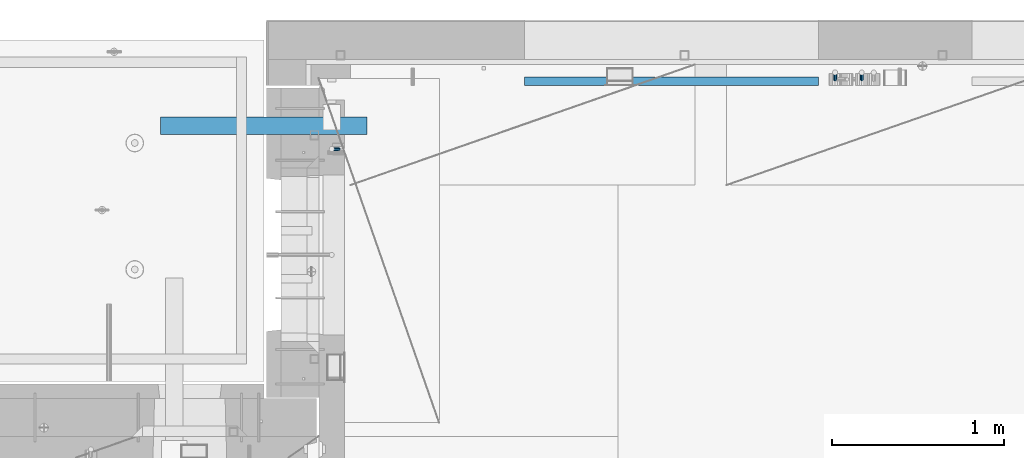
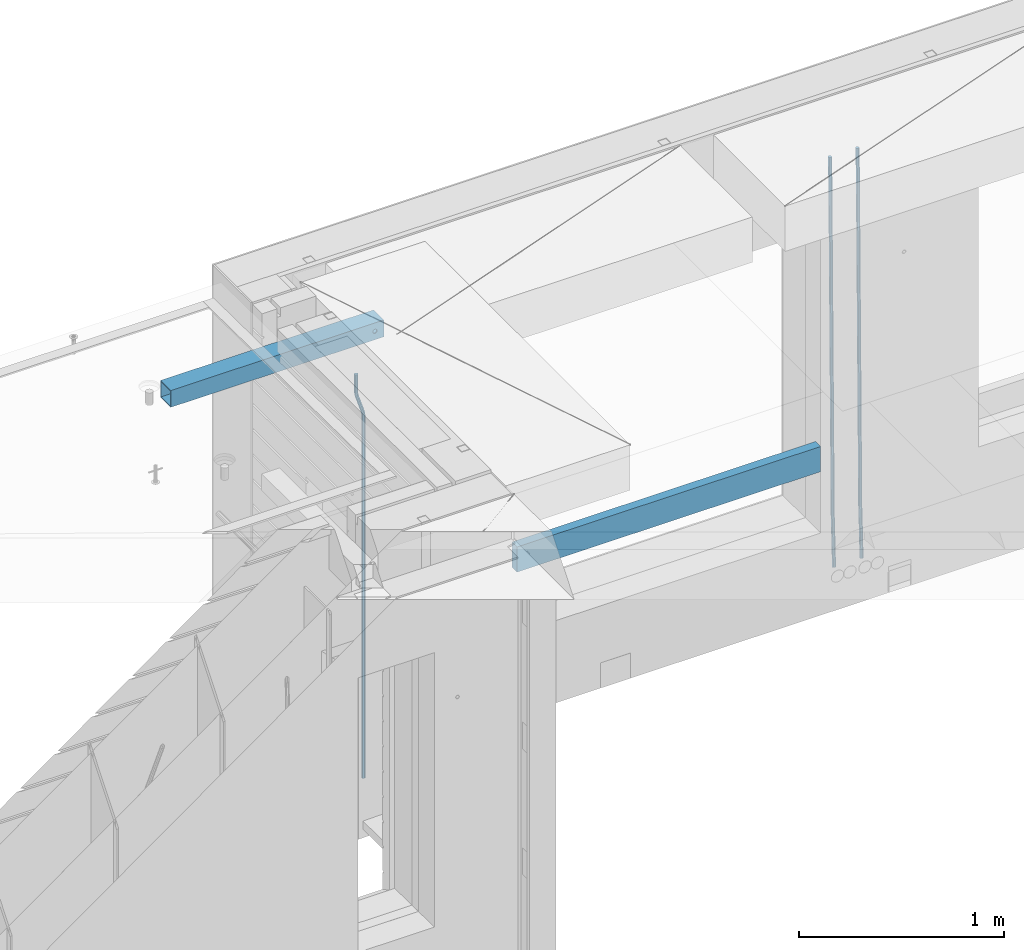
# One storey, part 111 of 334: 5 beams, 4 elements without a shape of their own.
"""IFC2X3 building model written with IfcOpenShell, lengths in millimetres."""

from ifc_helpers import new_model, si_unit, frame, origin_with_axes, place, context, subcontext, project, spatial, faceted_brep, material, type_object, element, aggregate, save


model = new_model("IFC2X3")

# Units and contexts
model_context = context("Model", 3, precision=1e-05, world=origin_with_axes())
body_context = subcontext(model_context, "Body", "Model", "MODEL_VIEW")
ifc_project = project(units=[si_unit("LENGTHUNIT", "METRE", prefix="MILLI"), si_unit("AREAUNIT", "SQUARE_METRE"), si_unit("VOLUMEUNIT", "CUBIC_METRE"), si_unit("MASSUNIT", "GRAM", prefix="KILO"), si_unit("TIMEUNIT", "SECOND"), si_unit("PLANEANGLEUNIT", "RADIAN"), si_unit("SOLIDANGLEUNIT", "STERADIAN"), si_unit("THERMODYNAMICTEMPERATUREUNIT", "DEGREE_CELSIUS"), si_unit("LUMINOUSINTENSITYUNIT", "LUMEN")], contexts=[model_context])

# Site, building, storey
site_placement = place(None, origin_with_axes())
site = spatial("IfcSite", under=ifc_project, at=site_placement, CompositionType="ELEMENT")
building_placement = place(site_placement, origin_with_axes())
building = spatial("IfcBuilding", under=site, at=building_placement, CompositionType="ELEMENT")
storey_placement = place(building_placement, origin_with_axes())
storey = spatial("IfcBuildingStorey", under=building, at=storey_placement, Name="3", CompositionType="ELEMENT", Elevation=0.0)

# Assembly, beams
assembly_1_placement = place(storey_placement, origin_with_axes())
assembly_1 = element("IfcElementAssembly", 1, at=assembly_1_placement, inside=storey, AssemblyPlace="NOTDEFINED", PredefinedType="REINFORCEMENT_UNIT")
ifc_material_1 = material()
beam_type_1 = type_object("IfcBeamType", Name="D20", PredefinedType="NOTDEFINED")
beam_1_placement = place(assembly_1_placement, frame((13990.0000000039, 22654.9999977209, 87990.0), z_axis=(-0.000205762999925498, 0.999642804629538, -0.0267249099901004), x_axis=(4.30000201928125e-08, 0.0267249099948059, 0.999642825806181)))
beam_1 = element("IfcBeam", 2, at=beam_1_placement, type_object=beam_type_1, material=ifc_material_1, Name="JM20", ObjectType="D20", context=body_context, shape_type="Brep", body=[
    faceted_brep([(0.0, -10.0, 0.0), (-4.19531716033816e-08, -7.07106781186667, -7.07106781187031), (60.4266690400545, -7.0710677960451, -7.07106780570757), (60.4266690441291, -9.99999998418934, 6.15546014159918e-09), (0.0, 0.0, -10.0), (60.426669036824, 1.58106558956206e-08, -9.99999999384454), (4.196772351861e-08, 7.07106781186303, -7.07106781186667), (60.4266690363438, 7.07106782768096, -7.07106780570757), (0.0, 10.0, 0.0), (60.4266690388904, 10.0000000158179, 6.15182216279209e-09), (4.196772351861e-08, 7.07106781185939, 7.07106781185939), (60.4266690429649, 7.07106782768096, 7.07106781802577), (0.0, 0.0, 10.0), (60.4266690461809, 1.58179318532348e-08, 10.0000000061555), (-4.19531716033816e-08, -7.07106781187031, 7.07106781185939), (60.4266690466611, -7.07106779605238, 7.07106781802213), (61.0378400410118, -7.07106779588503, -7.07106780564936), (60.991799419251, -9.99999998403655, 6.21366780251265e-09), (61.0569027789461, 1.5985278878361e-08, -9.99999999378269), (61.0378209396877, 7.07106782784831, -7.07106780564936), (60.9917724058905, 10.0000000159635, 6.21366780251265e-09), (60.9457317841297, 7.07106782781193, 7.0710678180767), (60.9266690461809, 1.59488990902901e-08, 10.0000000062028), (60.9457508854539, -7.07106779591413, 7.0710678180767), (61.6489592143771, -7.07106614513759, -7.06310863441468), (61.5568818710308, -9.9999984576425, 0.00735959856683621), (61.6870830769039, 1.71821739058942e-06, -9.99179257185824), (61.6489210170112, 7.07106947854481, -7.06310888312146), (61.556827851804, 10.0000015422847, 0.00735924683976918), (61.4647505084577, 7.07106922979438, 7.07782747982128), (61.4266266459163, 1.36643211590126e-06, 10.0065114172685), (61.464788705809, -7.07106639389531, 7.07782772852806), (176.543135720174, -7.07075579406956, -5.56673531796696), (176.451058376813, -9.99968810657447, 1.50373291501455), (176.581259582701, 0.000312069292704109, -8.49541925541052), (176.543097522794, 7.07137982961285, -5.56673556667374), (176.451004357587, 10.00031189336, 1.50373256329476), (176.35892701424, 7.07137958085514, 8.57420079627263), (176.320803151699, 0.000311717507429421, 11.5028847337162), (176.358965211621, -7.07075604281999, 8.57420104497578), (177.098753836006, -7.07075429323595, -5.55949898843028), (176.98362511232, -9.99968666800123, 1.510669025065), (177.146421932586, 0.000313595905026887, -8.48805862247536), (177.098706077581, 7.07138133041735, -5.55949936166144), (176.983557571715, 10.0003133318824, 1.51066849724157), (176.868428848029, 7.07138095712435, 8.58083651073321), (176.820760751449, 0.000313067976094317, 11.5093961447819), (176.868476606425, -7.07075466652896, 8.58083688396073), (177.654312950661, -7.07075204110879, -5.54863964998367), (177.516135294456, -9.99968450931192, 1.52107783331303), (177.711524267797, 0.000315886711177882, -8.47701274570863), (177.654255632195, 7.07138358250813, -5.54864021007961), (177.516054233929, 10.0003154905207, 1.5210770412159), (177.377876577739, 7.0713830223176, 8.59079452451624), (177.320665260588, 0.000315094497636892, 11.5191676202448), (177.377933896176, -7.07075260129932, 8.59079508461218), (299.436796249574, -7.07025836271714, -3.1681962331204), (299.298618593355, -9.99919083092027, 3.90152125031091), (299.494007566798, 0.000809565110102994, -6.09656932889993), (299.436738931283, 7.07187726089978, -3.16819679320906), (299.298537533061, 10.0008091689197, 3.90152045822106), (299.160359876842, 7.07187670072017, 10.9712379416487), (299.103148559603, 0.000808772889286047, 13.8996110374392), (299.160417195119, -7.07025892290039, 10.9712385017483), (299.98743051647, -7.07025613056248, -3.15743315966392), (299.971788958996, -9.99918809853989, 3.91467979818117), (299.993912075952, 0.000811591617093654, -6.08679785393178), (299.987423933868, 7.07187949325817, -3.1574327280432), (299.971753863239, 10.0008119014747, 3.91467990454839), (299.95611230444, 7.07187992653053, 10.9867922621015), (299.949630744944, 0.000812204350950196, 13.9161569563694), (299.956118887014, -7.07025569729012, 10.9867918304735), (300.538107039494, -7.07025785017686, -3.16575821840888), (300.644985195438, -9.99919020432935, 3.90450175465594), (300.493854948218, 0.000810030429420294, -6.09435592770024), (300.538151196495, 7.071877773491, -3.16575855385963), (300.645047642858, 10.0008097955724, 3.90450128024895), (300.751925798773, 7.07187744142357, 10.9747612533101), (300.796177890064, 0.000809560813650023, 13.9033589625978), (300.751881641787, -7.07025818224065, 10.9747615887682), (2293.36490490142, -7.07648090940347, -33.2930642912361), (2293.47178305736, -10.0054132635523, -26.2228043181785), (2293.32065281013, -0.00541302880083094, -36.2216620005347), (2293.36494905842, 7.06565471425711, -33.2930646266868), (2293.47184550477, 9.99458673634581, -26.2228047925819), (2293.57872366071, 7.06565438219332, -19.1525448195243), (2293.62297575199, -0.00541349841296324, -16.2239471102366), (2293.57867950371, -7.0764812414709, -19.1525444840736), (2294.0658245362, -7.07648309818615, -33.3036607065333), (2294.05312277409, -10.0054150789219, -26.2315929392535), (2294.10928714235, -0.00541549149056664, -36.2335844756526), (2294.15805078732, 7.06565223761572, -33.3050546393533), (2294.18355038921, 9.99458451388637, -26.2335642579346), (2294.17084862708, 7.06565253314329, -19.1614964906439), (2294.12738602093, -0.00541507354500936, -16.2315727215355), (2294.07862237596, -7.07648280265857, -19.1601025578348), (2294.76670261032, -7.08562269121467, -33.294332712383), (2294.63442802057, -10.0129954178956, -26.2238563411993), (2294.89787471293, -0.0156988342423574, -36.2230891548279), (2294.95110548967, 7.05531064255774, -33.2944998654275), (2294.89521307347, 9.98530428734011, -26.2240927312887), (2294.76293848372, 7.0579315606592, -19.1536163601049), (2294.63176638114, -0.0119922963167483, -16.2248599176673), (2294.57853560438, -7.08300177311321, -19.1534492070678), (2316.52657204497, -7.36937582653991, -33.0047303660212), (2316.39429745522, -10.2967485532172, -25.9342539948302), (2316.65774414754, -0.299451969567599, -35.9334868084661), (2316.7109749243, 6.7715575072325, -33.0048975190657), (2316.65508250811, 9.70155115201487, -25.9344903849269), (2316.52280791836, 6.7741784253376, -18.8640140137468), (2316.39163581574, -0.295745431634714, -15.9352575713092), (2316.33840503903, -7.36675490843481, -18.863846860706), (2317.16202064224, -7.37766220584308, -32.9962731735213), (2317.05438744847, -10.3053562613532, -25.9254688497131), (2317.23607125619, -0.306993473008333, -35.925789846493), (2317.23316144495, 6.76474808850253, -32.9979477328052), (2317.15499573652, 9.6950321815566, -25.9278370341635), (2317.04736254275, 6.7673381260538, -18.8570327103698), (2316.97331192881, -0.303330606784584, -15.9275160373909), (2316.97622174003, -7.37507216829545, -18.8553581510787), (2317.79752306276, -7.37578610372293, -32.9880110666527), (2317.71453320107, -10.3033876998124, -25.9168792378296), (2317.81444760226, -0.305295583297266, -35.918287695793), (2317.75539265381, 6.76628640723357, -32.9911928173897), (2317.65495180529, 9.69652304524061, -25.9213789128698), (2317.5719619436, 6.76892144914746, -18.8502470840467), (2317.55503740412, -0.301569071270933, -15.9199704549137), (2317.61409235255, -7.3731510618054, -18.847065333317), (2417.8183084176, -7.07752398473531, -31.6906369377139), (2417.73531855589, -10.0051255808248, -24.6195051088798), (2417.83523295709, -0.007033464313281, -34.6209135668432), (2417.77617800863, 7.06454852621755, -31.6938186884508), (2417.67573716014, 9.99478516423187, -24.6240047839383), (2417.59274729842, 7.06718356813872, -17.5528729551006), (2417.57582275895, -0.00330695228694822, -14.6225963259749), (2417.6348777074, -7.07488894281778, -17.5496912043673)], [[[0, 1, 2, 3]], [[1, 4, 5, 2]], [[4, 6, 7, 5]], [[6, 8, 9, 7]], [[8, 10, 11, 9]], [[10, 12, 13, 11]], [[12, 14, 15, 13]], [[14, 0, 3, 15]], [[14, 12, 10, 8, 6, 4, 1, 0]], [[3, 2, 16, 17]], [[2, 5, 18, 16]], [[5, 7, 19, 18]], [[7, 9, 20, 19]], [[9, 11, 21, 20]], [[11, 13, 22, 21]], [[13, 15, 23, 22]], [[15, 3, 17, 23]], [[17, 16, 24, 25]], [[16, 18, 26, 24]], [[18, 19, 27, 26]], [[19, 20, 28, 27]], [[20, 21, 29, 28]], [[21, 22, 30, 29]], [[22, 23, 31, 30]], [[23, 17, 25, 31]], [[25, 24, 32, 33]], [[24, 26, 34, 32]], [[26, 27, 35, 34]], [[27, 28, 36, 35]], [[28, 29, 37, 36]], [[29, 30, 38, 37]], [[30, 31, 39, 38]], [[31, 25, 33, 39]], [[33, 32, 40, 41]], [[32, 34, 42, 40]], [[34, 35, 43, 42]], [[35, 36, 44, 43]], [[36, 37, 45, 44]], [[37, 38, 46, 45]], [[38, 39, 47, 46]], [[39, 33, 41, 47]], [[41, 40, 48, 49]], [[40, 42, 50, 48]], [[42, 43, 51, 50]], [[43, 44, 52, 51]], [[44, 45, 53, 52]], [[45, 46, 54, 53]], [[46, 47, 55, 54]], [[47, 41, 49, 55]], [[49, 48, 56, 57]], [[48, 50, 58, 56]], [[50, 51, 59, 58]], [[51, 52, 60, 59]], [[52, 53, 61, 60]], [[53, 54, 62, 61]], [[54, 55, 63, 62]], [[55, 49, 57, 63]], [[57, 56, 64, 65]], [[56, 58, 66, 64]], [[58, 59, 67, 66]], [[59, 60, 68, 67]], [[60, 61, 69, 68]], [[61, 62, 70, 69]], [[62, 63, 71, 70]], [[63, 57, 65, 71]], [[65, 64, 72, 73]], [[64, 66, 74, 72]], [[66, 67, 75, 74]], [[67, 68, 76, 75]], [[68, 69, 77, 76]], [[69, 70, 78, 77]], [[70, 71, 79, 78]], [[71, 65, 73, 79]], [[73, 72, 80, 81]], [[72, 74, 82, 80]], [[74, 75, 83, 82]], [[75, 76, 84, 83]], [[76, 77, 85, 84]], [[77, 78, 86, 85]], [[78, 79, 87, 86]], [[79, 73, 81, 87]], [[81, 80, 88, 89]], [[80, 82, 90, 88]], [[82, 83, 91, 90]], [[83, 84, 92, 91]], [[84, 85, 93, 92]], [[85, 86, 94, 93]], [[86, 87, 95, 94]], [[87, 81, 89, 95]], [[89, 88, 96, 97]], [[88, 90, 98, 96]], [[90, 91, 99, 98]], [[91, 92, 100, 99]], [[92, 93, 101, 100]], [[93, 94, 102, 101]], [[94, 95, 103, 102]], [[95, 89, 97, 103]], [[97, 96, 104, 105]], [[96, 98, 106, 104]], [[98, 99, 107, 106]], [[99, 100, 108, 107]], [[100, 101, 109, 108]], [[101, 102, 110, 109]], [[102, 103, 111, 110]], [[103, 97, 105, 111]], [[105, 104, 112, 113]], [[104, 106, 114, 112]], [[106, 107, 115, 114]], [[107, 108, 116, 115]], [[108, 109, 117, 116]], [[109, 110, 118, 117]], [[110, 111, 119, 118]], [[111, 105, 113, 119]], [[113, 112, 120, 121]], [[112, 114, 122, 120]], [[114, 115, 123, 122]], [[115, 116, 124, 123]], [[116, 117, 125, 124]], [[117, 118, 126, 125]], [[118, 119, 127, 126]], [[119, 113, 121, 127]], [[121, 120, 128, 129]], [[120, 122, 130, 128]], [[122, 123, 131, 130]], [[123, 124, 132, 131]], [[124, 125, 133, 132]], [[125, 126, 134, 133]], [[126, 127, 135, 134]], [[127, 121, 129, 135]], [[130, 131, 132, 133, 134, 135, 129, 128]]]),
])
beam_2_placement = place(assembly_1_placement, frame((14145.0000000039, 22654.9999977209, 87990.0), z_axis=(-0.000205762999925498, 0.999642804629538, -0.0267249099901004), x_axis=(4.30000201928125e-08, 0.0267249099948059, 0.999642825806181)))
beam_2 = element("IfcBeam", 3, at=beam_2_placement, type_object=beam_type_1, material=ifc_material_1, Name="JM20", ObjectType="D20", context=body_context, shape_type="Brep", body=[
    faceted_brep([(0.0, -10.0, 0.0), (-4.19531716033816e-08, -7.07106781186667, -7.07106781187031), (60.4266690400545, -7.0710677960451, -7.07106780570757), (60.4266690441291, -9.99999998418934, 6.15546014159918e-09), (0.0, 0.0, -10.0), (60.426669036824, 1.58106558956206e-08, -9.99999999384454), (4.196772351861e-08, 7.07106781186303, -7.07106781186667), (60.4266690363438, 7.07106782768096, -7.07106780570757), (0.0, 10.0, 0.0), (60.4266690388904, 10.0000000158179, 6.15182216279209e-09), (4.196772351861e-08, 7.07106781185939, 7.07106781185939), (60.4266690429649, 7.07106782768096, 7.07106781802577), (0.0, 0.0, 10.0), (60.4266690461809, 1.58179318532348e-08, 10.0000000061555), (-4.19531716033816e-08, -7.07106781187031, 7.07106781185939), (60.4266690466611, -7.07106779605238, 7.07106781802213), (61.0378400410118, -7.07106779588503, -7.07106780564936), (60.991799419251, -9.99999998403655, 6.21366780251265e-09), (61.0569027789461, 1.5985278878361e-08, -9.99999999378269), (61.0378209396877, 7.07106782784831, -7.07106780564936), (60.9917724058905, 10.0000000159635, 6.21366780251265e-09), (60.9457317841297, 7.07106782781193, 7.0710678180767), (60.9266690461809, 1.59488990902901e-08, 10.0000000062028), (60.9457508854539, -7.07106779591413, 7.0710678180767), (61.6489592143771, -7.07106614513759, -7.06310863441468), (61.5568818710308, -9.9999984576425, 0.00735959856683621), (61.6870830769039, 1.71821739058942e-06, -9.99179257185824), (61.6489210170112, 7.07106947854481, -7.06310888312146), (61.556827851804, 10.0000015422847, 0.00735924683976918), (61.4647505084577, 7.07106922979438, 7.07782747982128), (61.4266266459163, 1.36643211590126e-06, 10.0065114172685), (61.464788705809, -7.07106639389531, 7.07782772852806), (176.543135720174, -7.07075579406956, -5.56673531796696), (176.451058376813, -9.99968810657447, 1.50373291501455), (176.581259582701, 0.000312069292704109, -8.49541925541052), (176.543097522794, 7.07137982961285, -5.56673556667374), (176.451004357587, 10.00031189336, 1.50373256329476), (176.35892701424, 7.07137958085514, 8.57420079627263), (176.320803151699, 0.000311717507429421, 11.5028847337162), (176.358965211621, -7.07075604281999, 8.57420104497578), (177.098753836006, -7.07075429323595, -5.55949898843028), (176.98362511232, -9.99968666800123, 1.510669025065), (177.146421932586, 0.000313595905026887, -8.48805862247536), (177.098706077581, 7.07138133041735, -5.55949936166144), (176.983557571715, 10.0003133318824, 1.51066849724157), (176.868428848029, 7.07138095712435, 8.58083651073321), (176.820760751449, 0.000313067976094317, 11.5093961447819), (176.868476606425, -7.07075466652896, 8.58083688396073), (177.654312950661, -7.07075204110879, -5.54863964998367), (177.516135294456, -9.99968450931192, 1.52107783331303), (177.711524267797, 0.000315886711177882, -8.47701274570863), (177.654255632195, 7.07138358250813, -5.54864021007961), (177.516054233929, 10.0003154905207, 1.5210770412159), (177.377876577739, 7.0713830223176, 8.59079452451624), (177.320665260588, 0.000315094497636892, 11.5191676202448), (177.377933896176, -7.07075260129932, 8.59079508461218), (299.436796249574, -7.07025836271714, -3.1681962331204), (299.298618593355, -9.99919083092027, 3.90152125031091), (299.494007566798, 0.000809565110102994, -6.09656932889993), (299.436738931283, 7.07187726089978, -3.16819679320906), (299.298537533061, 10.0008091689197, 3.90152045822106), (299.160359876842, 7.07187670072017, 10.9712379416487), (299.103148559603, 0.000808772889286047, 13.8996110374392), (299.160417195119, -7.07025892290039, 10.9712385017483), (299.98743051647, -7.07025613056248, -3.15743315966392), (299.971788958996, -9.99918809853989, 3.91467979818117), (299.993912075952, 0.000811591617093654, -6.08679785393178), (299.987423933868, 7.07187949325817, -3.1574327280432), (299.971753863239, 10.0008119014747, 3.91467990454839), (299.95611230444, 7.07187992653053, 10.9867922621015), (299.949630744944, 0.000812204350950196, 13.9161569563694), (299.956118887014, -7.07025569729012, 10.9867918304735), (300.538107039494, -7.07025785017686, -3.16575821840888), (300.644985195438, -9.99919020432935, 3.90450175465594), (300.493854948218, 0.000810030429420294, -6.09435592770024), (300.538151196495, 7.071877773491, -3.16575855385963), (300.645047642858, 10.0008097955724, 3.90450128024895), (300.751925798773, 7.07187744142357, 10.9747612533101), (300.796177890064, 0.000809560813650023, 13.9033589625978), (300.751881641787, -7.07025818224065, 10.9747615887682), (2293.36490490142, -7.07648090940347, -33.2930642912361), (2293.47178305736, -10.0054132635523, -26.2228043181785), (2293.32065281013, -0.00541302880083094, -36.2216620005347), (2293.36494905842, 7.06565471425711, -33.2930646266868), (2293.47184550477, 9.99458673634581, -26.2228047925819), (2293.57872366071, 7.06565438219332, -19.1525448195243), (2293.62297575199, -0.00541349841296324, -16.2239471102366), (2293.57867950371, -7.0764812414709, -19.1525444840736), (2294.0658245362, -7.07648309818615, -33.3036607065333), (2294.05312277409, -10.0054150789219, -26.2315929392535), (2294.10928714235, -0.00541549149056664, -36.2335844756526), (2294.15805078732, 7.06565223761572, -33.3050546393533), (2294.18355038921, 9.99458451388637, -26.2335642579346), (2294.17084862708, 7.06565253314329, -19.1614964906439), (2294.12738602093, -0.00541507354500936, -16.2315727215355), (2294.07862237596, -7.07648280265857, -19.1601025578348), (2294.76670261032, -7.08562269121467, -33.294332712383), (2294.63442802057, -10.0129954178956, -26.2238563411993), (2294.89787471293, -0.0156988342423574, -36.2230891548279), (2294.95110548967, 7.05531064255774, -33.2944998654275), (2294.89521307347, 9.98530428734011, -26.2240927312887), (2294.76293848372, 7.0579315606592, -19.1536163601049), (2294.63176638114, -0.0119922963167483, -16.2248599176673), (2294.57853560438, -7.08300177311321, -19.1534492070678), (2316.52657204497, -7.36937582653991, -33.0047303660212), (2316.39429745522, -10.2967485532172, -25.9342539948302), (2316.65774414754, -0.299451969567599, -35.9334868084661), (2316.7109749243, 6.7715575072325, -33.0048975190657), (2316.65508250811, 9.70155115201487, -25.9344903849269), (2316.52280791836, 6.7741784253376, -18.8640140137468), (2316.39163581574, -0.295745431634714, -15.9352575713092), (2316.33840503903, -7.36675490843481, -18.863846860706), (2317.16202064224, -7.37766220584308, -32.9962731735213), (2317.05438744847, -10.3053562613532, -25.9254688497131), (2317.23607125619, -0.306993473008333, -35.925789846493), (2317.23316144495, 6.76474808850253, -32.9979477328052), (2317.15499573652, 9.6950321815566, -25.9278370341635), (2317.04736254275, 6.7673381260538, -18.8570327103698), (2316.97331192881, -0.303330606784584, -15.9275160373909), (2316.97622174003, -7.37507216829545, -18.8553581510787), (2317.79752306276, -7.37578610372293, -32.9880110666527), (2317.71453320107, -10.3033876998124, -25.9168792378296), (2317.81444760226, -0.305295583297266, -35.918287695793), (2317.75539265381, 6.76628640723357, -32.9911928173897), (2317.65495180529, 9.69652304524061, -25.9213789128698), (2317.5719619436, 6.76892144914746, -18.8502470840467), (2317.55503740412, -0.301569071270933, -15.9199704549137), (2317.61409235255, -7.3731510618054, -18.847065333317), (2417.8183084176, -7.07752398473531, -31.6906369377139), (2417.73531855589, -10.0051255808248, -24.6195051088798), (2417.83523295709, -0.007033464313281, -34.6209135668432), (2417.77617800863, 7.06454852621755, -31.6938186884508), (2417.67573716014, 9.99478516423187, -24.6240047839383), (2417.59274729842, 7.06718356813872, -17.5528729551006), (2417.57582275895, -0.00330695228694822, -14.6225963259749), (2417.6348777074, -7.07488894281778, -17.5496912043673)], [[[0, 1, 2, 3]], [[1, 4, 5, 2]], [[4, 6, 7, 5]], [[6, 8, 9, 7]], [[8, 10, 11, 9]], [[10, 12, 13, 11]], [[12, 14, 15, 13]], [[14, 0, 3, 15]], [[14, 12, 10, 8, 6, 4, 1, 0]], [[3, 2, 16, 17]], [[2, 5, 18, 16]], [[5, 7, 19, 18]], [[7, 9, 20, 19]], [[9, 11, 21, 20]], [[11, 13, 22, 21]], [[13, 15, 23, 22]], [[15, 3, 17, 23]], [[17, 16, 24, 25]], [[16, 18, 26, 24]], [[18, 19, 27, 26]], [[19, 20, 28, 27]], [[20, 21, 29, 28]], [[21, 22, 30, 29]], [[22, 23, 31, 30]], [[23, 17, 25, 31]], [[25, 24, 32, 33]], [[24, 26, 34, 32]], [[26, 27, 35, 34]], [[27, 28, 36, 35]], [[28, 29, 37, 36]], [[29, 30, 38, 37]], [[30, 31, 39, 38]], [[31, 25, 33, 39]], [[33, 32, 40, 41]], [[32, 34, 42, 40]], [[34, 35, 43, 42]], [[35, 36, 44, 43]], [[36, 37, 45, 44]], [[37, 38, 46, 45]], [[38, 39, 47, 46]], [[39, 33, 41, 47]], [[41, 40, 48, 49]], [[40, 42, 50, 48]], [[42, 43, 51, 50]], [[43, 44, 52, 51]], [[44, 45, 53, 52]], [[45, 46, 54, 53]], [[46, 47, 55, 54]], [[47, 41, 49, 55]], [[49, 48, 56, 57]], [[48, 50, 58, 56]], [[50, 51, 59, 58]], [[51, 52, 60, 59]], [[52, 53, 61, 60]], [[53, 54, 62, 61]], [[54, 55, 63, 62]], [[55, 49, 57, 63]], [[57, 56, 64, 65]], [[56, 58, 66, 64]], [[58, 59, 67, 66]], [[59, 60, 68, 67]], [[60, 61, 69, 68]], [[61, 62, 70, 69]], [[62, 63, 71, 70]], [[63, 57, 65, 71]], [[65, 64, 72, 73]], [[64, 66, 74, 72]], [[66, 67, 75, 74]], [[67, 68, 76, 75]], [[68, 69, 77, 76]], [[69, 70, 78, 77]], [[70, 71, 79, 78]], [[71, 65, 73, 79]], [[73, 72, 80, 81]], [[72, 74, 82, 80]], [[74, 75, 83, 82]], [[75, 76, 84, 83]], [[76, 77, 85, 84]], [[77, 78, 86, 85]], [[78, 79, 87, 86]], [[79, 73, 81, 87]], [[81, 80, 88, 89]], [[80, 82, 90, 88]], [[82, 83, 91, 90]], [[83, 84, 92, 91]], [[84, 85, 93, 92]], [[85, 86, 94, 93]], [[86, 87, 95, 94]], [[87, 81, 89, 95]], [[89, 88, 96, 97]], [[88, 90, 98, 96]], [[90, 91, 99, 98]], [[91, 92, 100, 99]], [[92, 93, 101, 100]], [[93, 94, 102, 101]], [[94, 95, 103, 102]], [[95, 89, 97, 103]], [[97, 96, 104, 105]], [[96, 98, 106, 104]], [[98, 99, 107, 106]], [[99, 100, 108, 107]], [[100, 101, 109, 108]], [[101, 102, 110, 109]], [[102, 103, 111, 110]], [[103, 97, 105, 111]], [[105, 104, 112, 113]], [[104, 106, 114, 112]], [[106, 107, 115, 114]], [[107, 108, 116, 115]], [[108, 109, 117, 116]], [[109, 110, 118, 117]], [[110, 111, 119, 118]], [[111, 105, 113, 119]], [[113, 112, 120, 121]], [[112, 114, 122, 120]], [[114, 115, 123, 122]], [[115, 116, 124, 123]], [[116, 117, 125, 124]], [[117, 118, 126, 125]], [[118, 119, 127, 126]], [[119, 113, 121, 127]], [[121, 120, 128, 129]], [[120, 122, 130, 128]], [[122, 123, 131, 130]], [[123, 124, 132, 131]], [[124, 125, 133, 132]], [[125, 126, 134, 133]], [[126, 127, 135, 134]], [[127, 121, 129, 135]], [[130, 131, 132, 133, 134, 135, 129, 128]]]),
])

# Assembly, beam
assembly_2_placement = place(storey_placement, origin_with_axes())
assembly_2 = element("IfcElementAssembly", 4, at=assembly_2_placement, inside=storey, AssemblyPlace="NOTDEFINED", PredefinedType="REINFORCEMENT_UNIT")
beam_3_placement = place(assembly_2_placement, frame((11065.0, 22249.9963332647, 90407.5), z_axis=(0.999999913638316, -0.000415599999849952, 0.0), x_axis=(0.0, 0.0, -1.0)))
beam_3 = element("IfcBeam", 5, at=beam_3_placement, type_object=beam_type_1, material=ifc_material_1, Name="JM20", ObjectType="D20", context=body_context, shape_type="Brep", body=[
    faceted_brep([(0.0, -10.0, 0.0), (-4.19531716033816e-08, -7.07106781186667, -7.07106781187031), (113.248091332178, -7.0710684840451, -7.0710678117357), (113.248091314759, -10.0000006713562, -2.51020537689328e-10), (0.0, 0.0, -10.0), (113.248091374131, -6.72178430249915e-07, -9.99999999986903), (4.196772351861e-08, 7.07106781186303, -7.07106781186667), (113.248091416113, 7.07106713968824, -7.07106781173934), (0.0, 10.0, 0.0), (113.248091433488, 9.99999932782521, 1.30967237055302e-10), (4.196772351861e-08, 7.07106781185939, 7.07106781185939), (113.248091416113, 7.0710671396846, 7.071067811994), (0.0, 0.0, 10.0), (113.248091374131, -6.72174792271107e-07, 10.0000000001273), (-4.19531716033816e-08, -7.07106781187031, 7.07106781185939), (113.248091332178, -7.0710684840451, 7.071067811994), (130.699843527167, -7.06993249763036, -4.33745683788584), (128.538066582521, -9.99900540317321, 2.39499413731755), (131.594536475241, 0.00119355250353692, -7.12624594330919), (130.698046432328, 7.07220300913468, -4.33773834422391), (128.535525107087, 10.0009944322555, 2.39459602660281), (126.373748162892, 7.07192152754578, 9.1270470011732), (125.479055214906, 0.000795477419160306, 11.9158361066184), (126.37554525779, -7.07021397921199, 9.12732850753673), (240.336258550378, -7.05529970173666, 30.8729495437874), (238.174481606227, -9.98437260450009, 37.6054005176375), (241.230951498423, 0.0158263482953771, 28.0841604381058), (240.334461455612, 7.0868358050102, 30.8726680369582), (238.171940130502, 10.0156272283348, 37.6050024077231), (236.010163186409, 7.08655432384694, 44.3374533824244), (235.115470238379, 0.0154282738185429, 47.1262424881097), (236.011960281176, -7.05558118289991, 44.3377348892536), (253.461915329972, -7.05444528127919, 32.9289287376414), (253.46191532613, -9.98337746617108, 39.9999965521893), (253.461915339081, 0.0166225284556276, 29.9999965443676), (253.461915348205, 7.08769034247234, 32.9289287273205), (253.461915352003, 10.0166225357716, 39.9999965370152), (253.461915348293, 7.08769035281148, 47.0710643509774), (253.461915339183, 0.0166225430875784, 49.999996544273), (253.46191533003, -7.05444527093641, 47.0710643613093), (2417.50000002384, -7.0544364694706, 32.9289287374122), (2417.5000000337, -9.98336865393321, 39.9999965507959), (2417.49999999997, 0.0166313408753922, 29.9999965456082), (2417.49999997609, 7.08769915426274, 32.9289287300708), (2417.4999999662, 10.0166313460668, 39.9999965404204), (2417.49999997608, 7.08769916160054, 47.0710643538114), (2417.49999999994, 0.0166313512581837, 49.9999965456154), (2417.50000002382, -7.05443646212916, 47.0710643611455)], [[[0, 1, 2, 3]], [[1, 4, 5, 2]], [[4, 6, 7, 5]], [[6, 8, 9, 7]], [[8, 10, 11, 9]], [[10, 12, 13, 11]], [[12, 14, 15, 13]], [[14, 0, 3, 15]], [[14, 12, 10, 8, 6, 4, 1, 0]], [[3, 2, 16, 17]], [[2, 5, 18, 16]], [[5, 7, 19, 18]], [[7, 9, 20, 19]], [[9, 11, 21, 20]], [[11, 13, 22, 21]], [[13, 15, 23, 22]], [[15, 3, 17, 23]], [[17, 16, 24, 25]], [[16, 18, 26, 24]], [[18, 19, 27, 26]], [[19, 20, 28, 27]], [[20, 21, 29, 28]], [[21, 22, 30, 29]], [[22, 23, 31, 30]], [[23, 17, 25, 31]], [[25, 24, 32, 33]], [[24, 26, 34, 32]], [[26, 27, 35, 34]], [[27, 28, 36, 35]], [[28, 29, 37, 36]], [[29, 30, 38, 37]], [[30, 31, 39, 38]], [[31, 25, 33, 39]], [[33, 32, 40, 41]], [[32, 34, 42, 40]], [[34, 35, 43, 42]], [[35, 36, 44, 43]], [[36, 37, 45, 44]], [[37, 38, 46, 45]], [[38, 39, 47, 46]], [[39, 33, 41, 47]], [[42, 43, 44, 45, 46, 47, 41, 40]]]),
])
aggregate(assembly_2, [beam_3])

# Beam
ifc_material_2 = material(Name="TIMBER/T24")
beam_type_2 = type_object("IfcBeamType", PredefinedType="NOTDEFINED")
beam_4_placement = place(assembly_1_placement, frame((13895.0002980493, 22644.9998418812, 88685.0), z_axis=(0.0, 0.0, 1.0), x_axis=(-1.0, 3.00000001838171e-08, 0.0)))
beam_4 = element("IfcBeam", 6, at=beam_4_placement, type_object=beam_type_2, material=ifc_material_2, context=body_context, shape_type="Brep", body=[
    faceted_brep([(-3.63797880709171e-12, 24.9999999999964, -75.0), (-3.63797880709171e-12, 24.9999999999964, 75.0), (1710.0, 25.0, 75.0), (1710.0, 25.0, -75.0), (0.0, -25.0000000000073, 75.0), (1709.99999999999, -25.0, 75.0), (0.0, -25.0000000000073, -75.0), (1709.99999999999, -25.0, -75.0)], [[[0, 1, 2, 3]], [[1, 4, 5, 2]], [[4, 6, 7, 5]], [[6, 0, 3, 7]], [[5, 7, 3, 2]], [[6, 4, 1, 0]]]),
])

aggregate(assembly_1, [beam_1, beam_2, beam_4])

# Assemblies, beam
assembly_3_placement = place(storey_placement, origin_with_axes())
assembly_3 = element("IfcElementAssembly", 7, at=assembly_3_placement, inside=storey, AssemblyPlace="NOTDEFINED", PredefinedType="REINFORCEMENT_UNIT")
assembly_4_placement = place(assembly_3_placement, origin_with_axes())
assembly_4 = element("IfcElementAssembly", 8, at=assembly_4_placement, AssemblyPlace="NOTDEFINED", PredefinedType="NOTDEFINED")
aggregate(assembly_3, [assembly_4])
ifc_material_3 = material(Name="Undefined/350")
beam_type_3 = type_object("IfcBeamType", Name="100X100X5", PredefinedType="NOTDEFINED")
beam_5_placement = place(assembly_4_placement, frame((10069.9865573969, 22385.0401432011, 90555.0), z_axis=(0.0, 0.0, 1.0), x_axis=(0.999999999752625, -2.22429999942101e-05, 0.0)))
beam_5 = element("IfcBeam", 9, at=beam_5_placement, type_object=beam_type_3, material=ifc_material_3, ObjectType="100X100X5", context=body_context, shape_type="Brep", body=[
    faceted_brep([(1156.2510802317, 44.9999999999982, 10.8253175473074), (1156.25107855315, 50.0256005946221, 10.8253175473074), (1160.82639610046, 50.0256021227788, 6.25), (1160.82639777901, 44.9999999999982, 6.25), (1150.00108023171, 44.9999999999982, 12.5), (1150.00107855316, 50.0255985071226, 12.5), (1143.75108023171, 44.9999999999982, 10.8253175473074), (1143.75107855316, 50.0255964196231, 10.8253175473074), (1139.1757626844, 44.9999999999982, 6.25), (1139.17576100585, 50.0255948914664, 6.25), (1137.5010802317, 44.9999999999982, 0.0), (1137.50107855316, 50.0255943321226, 0.0), (1139.1757626844, 44.9999999999982, -6.25), (1139.17576100585, 50.0255948914664, -6.25), (1143.75108023171, 44.9999999999982, -10.8253175473074), (1143.75107855316, 50.0255964196231, -10.8253175473074), (1150.00108023171, 44.9999999999982, -12.5), (1150.00107855316, 50.0255985071226, -12.5), (1156.2510802317, 44.9999999999982, -10.8253175473074), (1156.25107855315, 50.0256005946221, -10.8253175473074), (1160.82639777901, 44.9999999999982, -6.25), (1160.82639610046, 50.0256021227788, -6.25), (1162.50108023171, 44.9999999999982, 0.0), (1162.50107855316, 50.0256026821226, 0.0), (1156.25111195316, -49.9743994042774, 10.8253175473074), (1156.25111029171, -44.9999999999991, 10.8253175473074), (1160.82642783901, -44.9999999999991, 6.25), (1160.82642950046, -49.9743978761207, 6.25), (1150.00111195316, -49.9744014917787, 12.5), (1150.00111029171, -44.9999999999991, 12.5), (1143.75111195316, -49.9744035792783, 10.8253175473074), (1143.75111029171, -44.9999999999991, 10.8253175473074), (1139.17579440585, -49.9744051074349, 6.25), (1139.1757927444, -44.9999999999991, 6.25), (1137.50111195316, -49.9744056667778, 0.0), (1137.50111029171, -44.9999999999991, 0.0), (1139.17579440585, -49.9744051074349, -6.25), (1139.1757927444, -44.9999999999991, -6.25), (1143.75111195316, -49.9744035792783, -10.8253175473074), (1143.75111029171, -44.9999999999991, -10.8253175473074), (1150.00111195316, -49.9744014917787, -12.5), (1150.00111029171, -44.9999999999991, -12.5), (1156.25111195316, -49.9743994042774, -10.8253175473074), (1156.25111029171, -44.9999999999991, -10.8253175473074), (1160.82642950046, -49.9743978761207, -6.25), (1160.82642783901, -44.9999999999991, -6.25), (1162.50111195316, -49.9743973167779, 0.0), (1162.50111029171, -44.9999999999991, 0.0), (1.81898940354586e-12, -50.0000000000009, -50.0), (1.81898940354586e-12, 49.9999999999991, -50.0), (1200.00449189278, 49.9999999999982, -50.0), (1200.00449189278, -50.0000000000009, -50.0), (1.81898940354586e-12, 49.9999999999991, 50.0), (1.81898940354586e-12, -50.0000000000009, 50.0), (1200.00449189278, -50.0000000000009, 50.0), (1200.00449189278, 49.9999999999982, 50.0), (0.0, 44.9999999999991, 45.0), (1.81898940354586e-12, -45.0000000000009, 45.0), (1.81898940354586e-12, -45.0000000000009, -45.0), (0.0, 44.9999999999991, -45.0), (1200.00449189278, 44.9999999999982, -45.0), (1200.00449189278, 44.9999999999982, 45.0), (1200.00449189278, -45.0000000000009, 45.0), (1200.00449189278, -45.0000000000009, -45.0)], [[[0, 1, 2, 3]], [[4, 5, 1, 0]], [[6, 7, 5, 4]], [[8, 9, 7, 6]], [[10, 11, 9, 8]], [[12, 13, 11, 10]], [[14, 15, 13, 12]], [[16, 17, 15, 14]], [[18, 19, 17, 16]], [[20, 21, 19, 18]], [[22, 23, 21, 20]], [[3, 2, 23, 22]], [[24, 25, 26, 27]], [[28, 29, 25, 24]], [[30, 31, 29, 28]], [[32, 33, 31, 30]], [[34, 35, 33, 32]], [[36, 37, 35, 34]], [[38, 39, 37, 36]], [[40, 41, 39, 38]], [[42, 43, 41, 40]], [[44, 45, 43, 42]], [[46, 47, 45, 44]], [[27, 26, 47, 46]], [[48, 49, 50, 51]], [[52, 53, 54, 55]], [[49, 52, 55, 50], [1, 5, 7, 9, 11, 13, 15, 17, 19, 21, 23, 2]], [[48, 53, 52, 49], [56, 57, 58, 59]], [[56, 59, 60, 61], [18, 16, 14, 12, 10, 8, 6, 4, 0, 3, 22, 20]], [[57, 56, 61, 62]], [[58, 57, 62, 63], [25, 29, 31, 33, 35, 37, 39, 41, 43, 45, 47, 26]], [[59, 58, 63, 60]], [[54, 51, 50, 55], [62, 61, 60, 63]], [[53, 48, 51, 54], [42, 40, 38, 36, 34, 32, 30, 28, 24, 27, 46, 44]]]),
])
aggregate(assembly_4, [beam_5])

save(model, "model.ifc")
